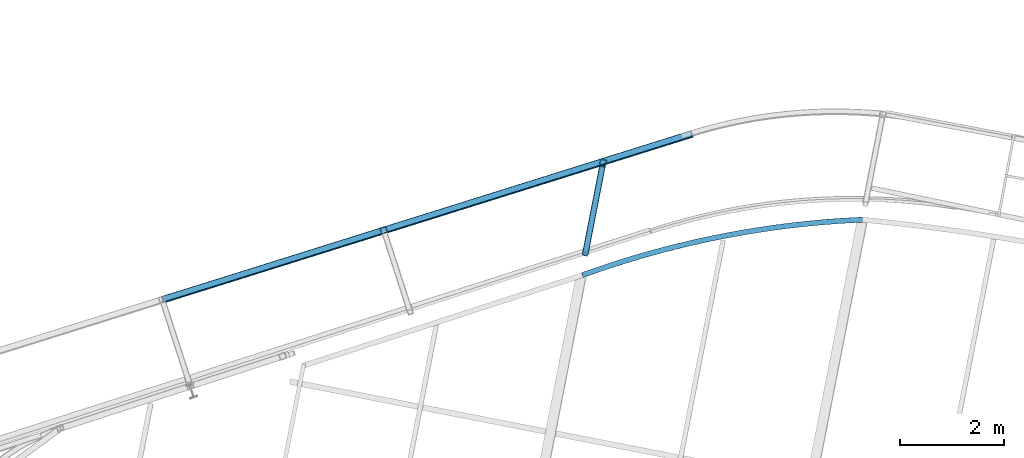
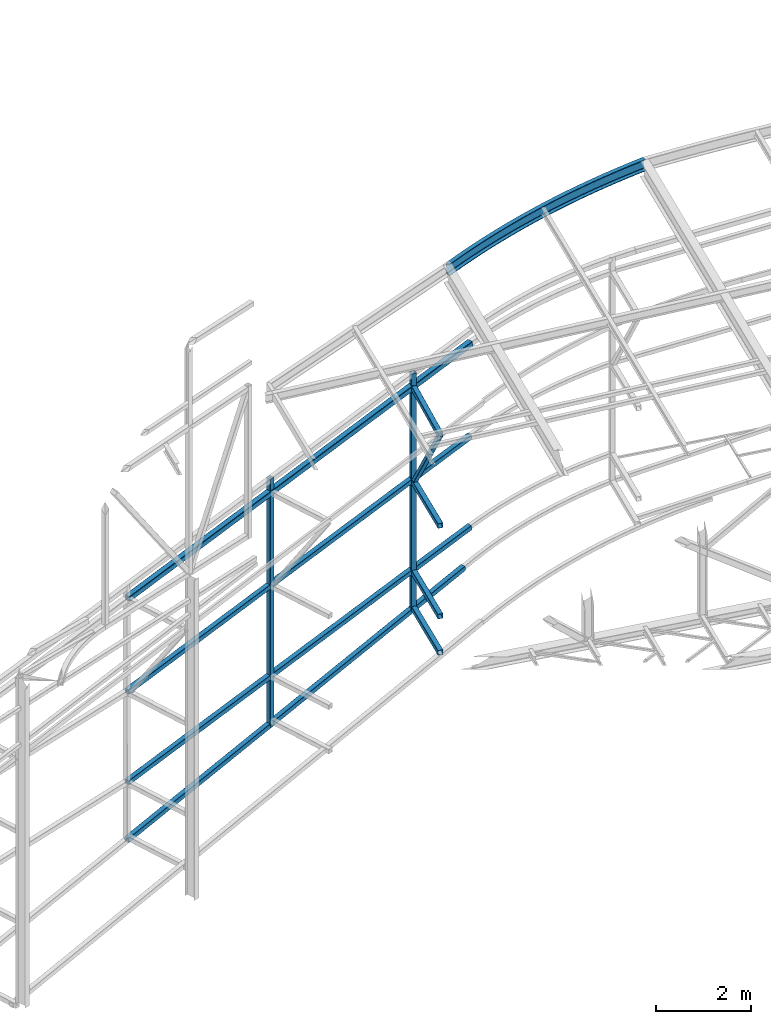
# One storey, part 86 of 215: 11 beams, 1 member, 12 elements without a shape of their own.
"""IFC2X3 building model written with IfcOpenShell, lengths in millimetres."""

from ifc_helpers import new_model, entity, si_unit, frame, origin_with_axes, origin_2d_with_axis, place, context, subcontext, project, spatial, hollow_rectangle, extrude, clip, halfspace, material, type_object, element, aggregate, save


model = new_model("IFC2X3")

# Units and contexts
model_context = context("Model", 3, precision=1e-05, world=origin_with_axes())
body_context = subcontext(model_context, "Body", "Model", "MODEL_VIEW")
ifc_project = project(units=[si_unit("LENGTHUNIT", "METRE", prefix="MILLI"), si_unit("AREAUNIT", "SQUARE_METRE"), si_unit("VOLUMEUNIT", "CUBIC_METRE"), si_unit("MASSUNIT", "GRAM", prefix="KILO"), si_unit("TIMEUNIT", "SECOND"), si_unit("PLANEANGLEUNIT", "RADIAN"), si_unit("SOLIDANGLEUNIT", "STERADIAN"), si_unit("THERMODYNAMICTEMPERATUREUNIT", "DEGREE_CELSIUS"), si_unit("LUMINOUSINTENSITYUNIT", "LUMEN")], contexts=[model_context])

# Site, building, storey
site_placement = place(None, origin_with_axes())
site = spatial("IfcSite", under=ifc_project, at=site_placement, CompositionType="ELEMENT")
building_placement = place(site_placement, origin_with_axes())
building = spatial("IfcBuilding", under=site, at=building_placement, Name="Undefined", CompositionType="ELEMENT")
storey_placement = place(building_placement, origin_with_axes())
storey = spatial("IfcBuildingStorey", under=building, at=storey_placement, Name="Undefined", CompositionType="ELEMENT", Elevation=0.0)

# Assembly, beam
assembly_1_placement = place(storey_placement, origin_with_axes())
assembly_1 = element("IfcElementAssembly", 1, at=assembly_1_placement, inside=storey, Name="Steel Assembly", AssemblyPlace="NOTDEFINED", PredefinedType="RIGID_FRAME")
ifc_material_1 = material(Name="STEEL/S275JR")
beam_type_1 = type_object("IfcBeamType", PredefinedType="NOTDEFINED")
beam_1_placement = place(assembly_1_placement, frame((51283.5824291176, 62330.9941440248, 7602.0533905139), z_axis=(0.308275434998926, -0.951297143996671, -1.00000033853226e-09), x_axis=(0.0, 0.0, -1.0)))
beam_1 = element("IfcBeam", 2, at=beam_1_placement, type_object=beam_type_1, material=ifc_material_1, Name="MONTANT", context=body_context, shape_type="SweptSolid", body=[
    extrude(hollow_rectangle(XDim=120.0, YDim=120.0, WallThickness=5.0, InnerFilletRadius=5.0, OuterFilletRadius=10.0, at=origin_2d_with_axis()), frame((6369.27675582869, 0.0, 7.27595761418343e-12), z_axis=(-1.0, 0.0, 0.0), x_axis=(-6.93889390390723e-18, -1.0, -3.46944695195361e-18)), (0.0, 0.0, 1.0), 6369.3),
])
aggregate(assembly_1, [beam_1])

assembly_2_placement = place(storey_placement, origin_with_axes())
assembly_2 = element("IfcElementAssembly", 3, at=assembly_2_placement, inside=storey, Name="Steel Assembly", AssemblyPlace="NOTDEFINED", PredefinedType="RIGID_FRAME")
beam_2_placement = place(assembly_2_placement, frame((55493.027873327, 63622.2850926627, 8041.48082727082), z_axis=(-0.191859508000518, -0.981422401002646, -1.00000033853845e-09), x_axis=(0.0, 0.0, -1.0)))
beam_2 = element("IfcBeam", 4, at=beam_2_placement, type_object=beam_type_1, material=ifc_material_1, Name="MONTANT", context=body_context, shape_type="Clipping", body=[
    clip(extrude(hollow_rectangle(XDim=120.0, YDim=120.0, WallThickness=5.0, InnerFilletRadius=5.0, OuterFilletRadius=10.0, at=origin_2d_with_axis()), frame((6078.74005856893, 0.0, 0.0), z_axis=(-1.0, 0.0, 0.0), x_axis=(-6.93889390390723e-18, -1.0, -3.46944695195361e-18)), (0.0, 0.0, 1.0), 6078.7), halfspace(frame((6040.73132857216, 104.946029856364, -157.245403169029), z_axis=(0.988585726359215, 0.132420408469063, -0.0718546940687163), x_axis=(9.70443580138805e-10, -0.47693462273527, -0.878938772404748)), False)),
])
aggregate(assembly_2, [beam_2])

assembly_3_placement = place(storey_placement, origin_with_axes())
assembly_3 = element("IfcElementAssembly", 5, at=assembly_3_placement, inside=storey, Name="Steel Assembly", AssemblyPlace="NOTDEFINED", PredefinedType="RIGID_FRAME")
ifc_material_2 = material(Name="STEEL/S235JR")
beam_3_placement = place(assembly_3_placement, frame((57194.7670779336, 64183.2349537095, 5466.24307387477), z_axis=(-0.298979127924315, 0.954259650758438, 0.0), x_axis=(-0.94951750190194, -0.297493365969277, -0.099570129989717)))
beam_3 = element("IfcBeam", 6, at=beam_3_placement, type_object=beam_type_1, material=ifc_material_2, Name="LISSE", context=body_context, shape_type="SweptSolid", body=[
    extrude(hollow_rectangle(XDim=120.0, YDim=120.0, WallThickness=5.0, InnerFilletRadius=5.0, OuterFilletRadius=10.0, at=origin_2d_with_axis()), frame((10694.4325298964, 7.61079636398037e-13, -7.5917734146245e-12), z_axis=(-1.0, 0.0, 0.0), x_axis=(-6.93889390390723e-18, -1.0, -3.46944695195361e-18)), (0.0, 0.0, 1.0), 10694.4),
])
aggregate(assembly_3, [beam_3])

assembly_4_placement = place(storey_placement, origin_with_axes())
assembly_4 = element("IfcElementAssembly", 7, at=assembly_4_placement, inside=storey, Name="Steel Assembly", AssemblyPlace="NOTDEFINED", PredefinedType="RIGID_FRAME")
beam_4_placement = place(assembly_4_placement, frame((57194.7670779805, 64183.2349537196, 3142.29008969048), z_axis=(-0.298979127924315, 0.954259650758438, 0.0), x_axis=(-0.949516543091714, -0.297493066028735, -0.0995801690096185)))
beam_4 = element("IfcBeam", 8, at=beam_4_placement, type_object=beam_type_1, material=ifc_material_2, Name="LISSE", context=body_context, shape_type="SweptSolid", body=[
    extrude(hollow_rectangle(XDim=120.0, YDim=120.0, WallThickness=5.0, InnerFilletRadius=5.0, OuterFilletRadius=10.0, at=origin_2d_with_axis()), frame((10694.4433285008, 0.0, 3.84309163385065e-13), z_axis=(-1.0, 0.0, 0.0), x_axis=(-6.93889390390723e-18, -1.0, -3.46944695195361e-18)), (0.0, 0.0, 1.0), 10694.4),
])
aggregate(assembly_4, [beam_4])

assembly_5_placement = place(storey_placement, origin_with_axes())
assembly_5 = element("IfcElementAssembly", 9, at=assembly_5_placement, inside=storey, Name="Steel Assembly", AssemblyPlace="NOTDEFINED", PredefinedType="RIGID_FRAME")
beam_5_placement = place(assembly_5_placement, frame((47031.5195035536, 60999.0238847309, 598.376308663375), z_axis=(-0.298860041108101, 0.95429678534518, -0.000566841000204988), x_axis=(0.943243378833732, 0.295488451947913, 0.151586618973279)))
beam_5 = element("IfcBeam", 10, at=beam_5_placement, type_object=beam_type_1, material=ifc_material_1, Name="LISSE", context=body_context, shape_type="SweptSolid", body=[
    extrude(hollow_rectangle(XDim=120.0, YDim=120.0, WallThickness=5.0, InnerFilletRadius=5.0, OuterFilletRadius=10.0, at=origin_2d_with_axis()), frame((10573.763775541, 0.0, -7.64954389657407e-12), z_axis=(-1.0, 0.0, 0.0), x_axis=(-6.93889390390723e-18, -1.0, -3.46944695195361e-18)), (0.0, 0.0, 1.0), 10573.8),
])
aggregate(assembly_5, [beam_5])

assembly_6_placement = place(storey_placement, origin_with_axes())
assembly_6 = element("IfcElementAssembly", 11, at=assembly_6_placement, inside=storey, Name="Steel Assembly", AssemblyPlace="NOTDEFINED", PredefinedType="RIGID_FRAME")
beam_6_placement = place(assembly_6_placement, frame((55477.6791114423, 63543.7713078685, 2029.94321774467), z_axis=(-0.981422412140383, 0.191859451027444, 0.0), x_axis=(-0.191859508000518, -0.981422401002646, -1.00000033853845e-09)))
beam_6 = element("IfcBeam", 12, at=beam_6_placement, type_object=beam_type_1, material=ifc_material_1, context=body_context, shape_type="SweptSolid", body=[
    extrude(hollow_rectangle(XDim=120.0, YDim=120.0, WallThickness=5.0, InnerFilletRadius=5.0, OuterFilletRadius=10.0, at=origin_2d_with_axis()), frame((1703.6208174664, -7.04601055674975e-22, -2.0433430362183e-29), z_axis=(-1.0, 0.0, 0.0), x_axis=(-6.93889390390723e-18, -1.0, -3.46944695195361e-18)), (0.0, 0.0, 1.0), 1703.6),
])
aggregate(assembly_6, [beam_6])

assembly_7_placement = place(storey_placement, origin_with_axes())
assembly_7 = element("IfcElementAssembly", 13, at=assembly_7_placement, inside=storey, Name="Steel Assembly", AssemblyPlace="NOTDEFINED", PredefinedType="RIGID_FRAME")
beam_7_placement = place(assembly_7_placement, frame((55477.6791113968, 63543.7713053402, 5283.05140896703), z_axis=(-0.981422412140383, 0.191859451027444, 0.0), x_axis=(-0.191859508000518, -0.981422401002646, -1.00000033853845e-09)))
beam_7 = element("IfcBeam", 14, at=beam_7_placement, type_object=beam_type_1, material=ifc_material_1, context=body_context, shape_type="SweptSolid", body=[
    extrude(hollow_rectangle(XDim=120.0, YDim=120.0, WallThickness=5.0, InnerFilletRadius=5.0, OuterFilletRadius=10.0, at=origin_2d_with_axis()), frame((1703.6208174664, -7.04601055674975e-22, -2.0433430362183e-29), z_axis=(-1.0, 0.0, 0.0), x_axis=(-6.93889390390723e-18, -1.0, -3.46944695195361e-18)), (0.0, 0.0, 1.0), 1703.6),
])
aggregate(assembly_7, [beam_7])

assembly_8_placement = place(storey_placement, origin_with_axes())
assembly_8 = element("IfcElementAssembly", 15, at=assembly_8_placement, inside=storey, Name="Steel Assembly", AssemblyPlace="NOTDEFINED", PredefinedType="RIGID_FRAME")
beam_8_placement = place(assembly_8_placement, frame((55477.6791113997, 63543.7713045639, 2959.17472640882), z_axis=(-0.981422412140383, 0.191859451027444, 0.0), x_axis=(-0.191859508000518, -0.981422401002646, -1.00000033853845e-09)))
beam_8 = element("IfcBeam", 16, at=beam_8_placement, type_object=beam_type_1, material=ifc_material_1, context=body_context, shape_type="SweptSolid", body=[
    extrude(hollow_rectangle(XDim=120.0, YDim=120.0, WallThickness=5.0, InnerFilletRadius=5.0, OuterFilletRadius=10.0, at=origin_2d_with_axis()), frame((1703.6208174664, -7.04601055674975e-22, -2.0433430362183e-29), z_axis=(-1.0, 0.0, 0.0), x_axis=(-6.93889390390723e-18, -1.0, -3.46944695195361e-18)), (0.0, 0.0, 1.0), 1703.6),
])
aggregate(assembly_8, [beam_8])

assembly_9_placement = place(storey_placement, origin_with_axes())
assembly_9 = element("IfcElementAssembly", 17, at=assembly_9_placement, inside=storey, Name="Steel Assembly", AssemblyPlace="NOTDEFINED", PredefinedType="RIGID_FRAME")
beam_9_placement = place(assembly_9_placement, frame((55478.2258211561, 63546.5678916637, 7681.93976141378), z_axis=(-0.981422412140383, 0.191859451027444, 0.0), x_axis=(-0.191642924051113, -0.980314993261454, -0.0474921430126665)))
beam_9 = element("IfcBeam", 18, at=beam_9_placement, type_object=beam_type_1, material=ifc_material_1, context=body_context, shape_type="SweptSolid", body=[
    extrude(hollow_rectangle(XDim=120.0, YDim=120.0, WallThickness=5.0, InnerFilletRadius=5.0, OuterFilletRadius=10.0, at=origin_2d_with_axis()), frame((1705.54532875706, -1.18345980845498e-14, -2.05540375061946e-14), z_axis=(-1.0, 0.0, 0.0), x_axis=(-6.93889390390723e-18, -1.0, -3.46944695195361e-18)), (0.0, 0.0, 1.0), 1705.5),
])
aggregate(assembly_9, [beam_9])

# Assembly, member
assembly_10_placement = place(storey_placement, origin_with_axes())
assembly_10 = element("IfcElementAssembly", 19, at=assembly_10_placement, inside=storey, Name="Steel Assembly", AssemblyPlace="NOTDEFINED", PredefinedType="RIGID_FRAME")
member_type = type_object("IfcMemberType", PredefinedType="NOTDEFINED")
member_placement = place(assembly_10_placement, frame((55151.187888157, 61873.6640414749, 7620.91719097398), z_axis=(-0.9789200986653, 0.204042848930233, 0.00905296799690467), x_axis=(0.112909415980848, 0.57756785690203, -0.808496650862859)))
member = element("IfcMember", 20, at=member_placement, type_object=member_type, material=ifc_material_1, context=body_context, shape_type="SweptSolid", body=[
    extrude(hollow_rectangle(XDim=100.0, YDim=100.0, WallThickness=5.0, InnerFilletRadius=5.0, OuterFilletRadius=10.0, at=origin_2d_with_axis()), frame((2891.62086126274, -7.43647481711644e-12, 7.26090912640846e-12), z_axis=(-1.0, 0.0, 0.0), x_axis=(-6.93889390390723e-18, -1.0, -3.46944695195361e-18)), (0.0, 0.0, 1.0), 2891.6),
])
aggregate(assembly_10, [member])

# Assembly, beam
assembly_11_placement = place(storey_placement, origin_with_axes())
assembly_11 = element("IfcElementAssembly", 21, at=assembly_11_placement, inside=storey, Name="Steel Assembly", AssemblyPlace="NOTDEFINED", PredefinedType="RIGID_FRAME")
beam_type_2 = type_object("IfcBeamType", PredefinedType="NOTDEFINED")
beam_10_placement = place(assembly_11_placement, frame((57204.5236385467, 64175.3916850169, 7858.95860623196), z_axis=(-0.298979127924315, 0.954259650758438, 0.0), x_axis=(-0.949525336614361, -0.297495820879175, -0.0994880479595941)))
beam_10 = element("IfcBeam", 22, at=beam_10_placement, type_object=beam_type_2, material=ifc_material_2, Name="LISSE", context=body_context, shape_type="SweptSolid", body=[
    extrude(hollow_rectangle(XDim=140.0, YDim=140.0, WallThickness=8.0, InnerFilletRadius=12.0, OuterFilletRadius=20.0, at=origin_2d_with_axis()), frame((10694.3442872525, -3.47270030405867e-14, 3.99670708637704e-13), z_axis=(-1.0, 0.0, 0.0), x_axis=(-6.93889390390723e-18, -1.0, -3.46944695195361e-18)), (0.0, 0.0, 1.0), 10694.3),
])
aggregate(assembly_11, [beam_10])

assembly_12_placement = place(storey_placement, origin_with_axes())
assembly_12 = element("IfcElementAssembly", 23, at=assembly_12_placement, inside=storey, Name="Steel Assembly", AssemblyPlace="NOTDEFINED", PredefinedType="RIGID_FRAME")
beam_type_3 = type_object("IfcBeamType", Name="UPE300", PredefinedType="NOTDEFINED")
beam_11_placement = place(assembly_12_placement, frame((55102.3687219904, 61467.2464011272, 12126.9422530335), z_axis=(-0.0303730969858543, -0.006000008997208, 0.999520622534383), x_axis=(0.980571089678735, 0.193705479936536, 0.0309600569898564)))
beam_11 = element("IfcBeam", 24, at=beam_11_placement, type_object=beam_type_3, material=ifc_material_1, Name="POUTRE", ObjectType="UPE300", context=body_context, shape_type="SweptSolid", body=[
    entity("IfcRevolvedAreaSolid", entity("IfcUShapeProfileDef", "AREA", None, entity("IfcAxis2Placement2D", entity("IfcCartesianPoint", [0.0, 0.0]), entity("IfcDirection", [1.0, 0.0])), 300.0, 100.0, 9.5, 15.0, 15.0), entity("IfcAxis2Placement3D", entity("IfcCartesianPoint", [5483.0034104071, 1.12081111683163e-14, -1.78094342460628e-12]), entity("IfcDirection", [-0.988267968540176, 0.15272990001134, -6.96961234422668e-18]), entity("IfcDirection", [-0.15272990001134, -0.988267968540176, -3.34245429100679e-19])), entity("IfcAxis1Placement", entity("IfcCartesianPoint", [17950.0, 0.0, 0.0]), entity("IfcDirection", [0.0, 1.0, 0.0])), 0.306659988838921),
])
aggregate(assembly_12, [beam_11])

save(model, "model.ifc")
